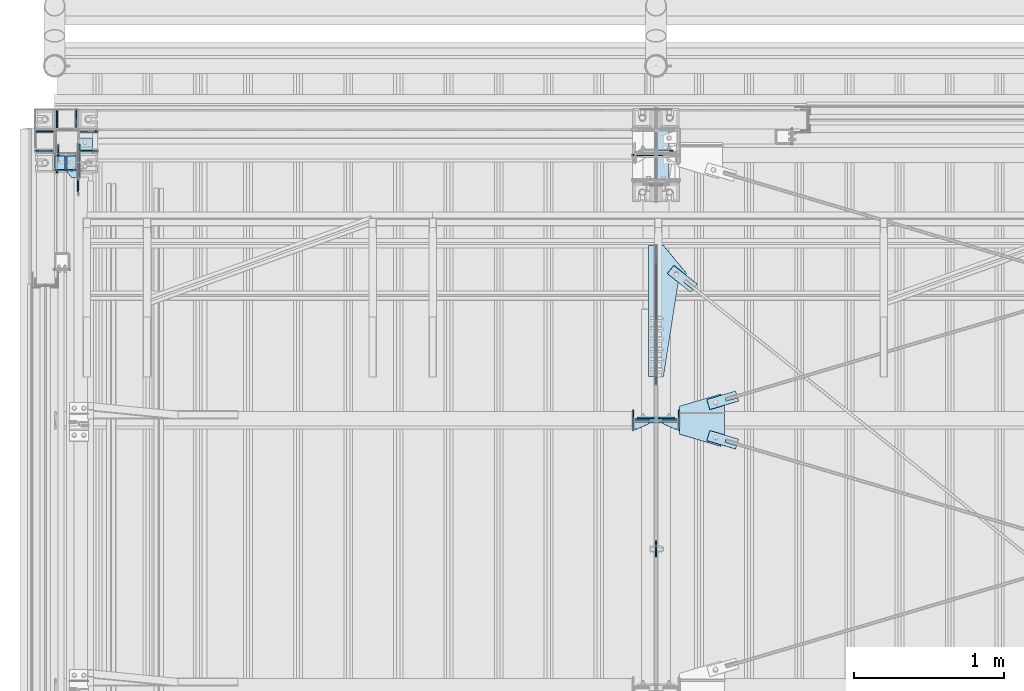
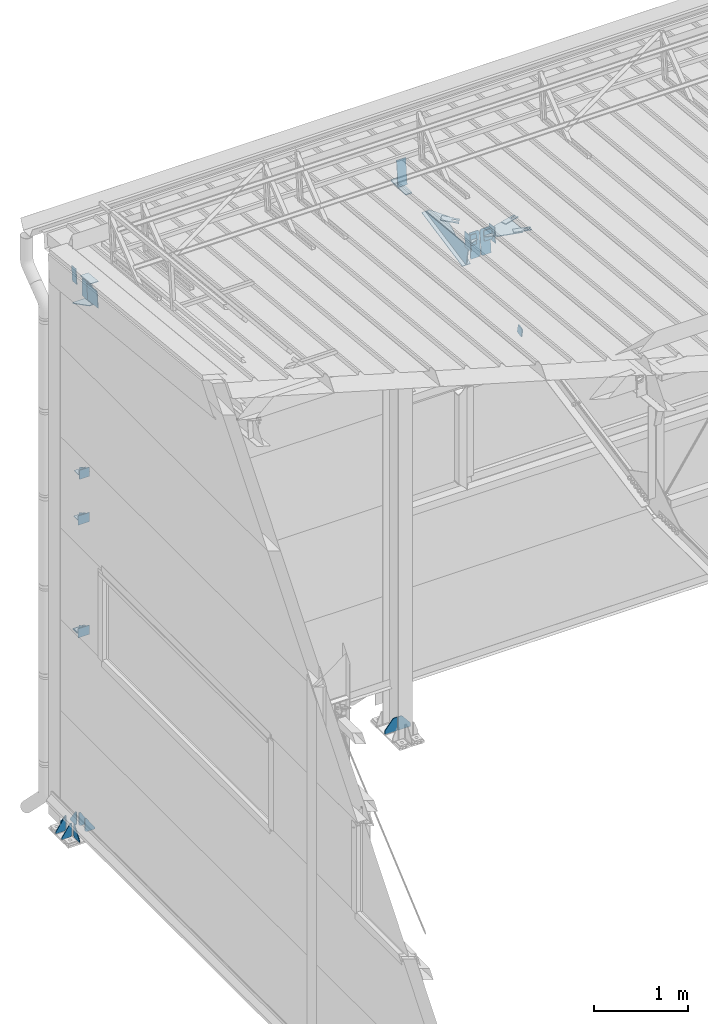
# One storey, part 132 of 709: 41 plates, 2 openings, 14 elements without a shape of their own.
"""IFC4 building model written with IfcOpenShell, lengths in millimetres."""

from ifc_helpers import new_model, si_unit, direction, frame, origin_with_axes, place, context, subcontext, project, spatial, line, indexed_curve, outline, extrude, material, element, aggregate, save


model = new_model("IFC4")

# Units and contexts
model_context = context("Model", 3, precision=0.2, world=origin_with_axes(), true_north=direction((0.0, 1.0)))
body_context = subcontext(model_context, "Body", "Model", "MODEL_VIEW")
ifc_project = project(units=[si_unit("LENGTHUNIT", "METRE", prefix="MILLI"), si_unit("AREAUNIT", "SQUARE_METRE"), si_unit("VOLUMEUNIT", "CUBIC_METRE"), si_unit("MASSUNIT", "GRAM", prefix="KILO"), si_unit("TIMEUNIT", "SECOND"), si_unit("PLANEANGLEUNIT", "RADIAN"), si_unit("SOLIDANGLEUNIT", "STERADIAN"), si_unit("THERMODYNAMICTEMPERATUREUNIT", "DEGREE_CELSIUS"), si_unit("LUMINOUSINTENSITYUNIT", "LUMEN")], contexts=[model_context])

# Site, building, storey
site_placement = place(None, origin_with_axes())
site = spatial("IfcSite", under=ifc_project, at=site_placement, CompositionType="ELEMENT")
building_placement = place(site_placement, origin_with_axes())
building = spatial("IfcBuilding", under=site, at=building_placement, Name="Undefined", CompositionType="ELEMENT")
storey_placement = place(building_placement, origin_with_axes())
storey = spatial("IfcBuildingStorey", under=building, at=storey_placement, Name="Undefined", CompositionType="ELEMENT", Elevation=0.0)

# Assembly, plates
assembly_1_placement = place(storey_placement, frame((4000.0, 21827.0, -200.0), z_axis=(-1.0, 0.0, 0.0), x_axis=(0.0, 0.0, 1.0)))
assembly_1 = element("IfcElementAssembly", 1, at=assembly_1_placement, inside=storey)
ifc_material = material(Name="C355-6", Category="STEEL")
plate_1_placement = place(assembly_1_placement, frame((7434.21546, 30.02526, -3.0), z_axis=(-0.099503719, 0.9950371902, 0.0), x_axis=(0.0, 0.0, -1.0)))
plate_1 = element("IfcPlate", 2, at=plate_1_placement, material=ifc_material, ObjectType="595", context=body_context, shape_type="SolidModel", body=[
    extrude(outline(indexed_curve([(0.0, 0.0), (114.0, 0.0), (114.0, 333.33554), (0.0, 333.33554)], segments=[line(1, 2, 3, 4, 1)])), frame((0.0, 0.0, 4.0), z_axis=(0.0, 0.0, 1.0), x_axis=(1.0, 0.0, 0.0)), (0.0, 0.0, -1.0), 8.0),
])
plate_2_placement = place(assembly_1_placement, frame((7097.93718, -163.0, -87.0), z_axis=(-1.0, 0.0, 0.0), x_axis=(0.0, 0.0, 1.0)))
plate_2 = element("IfcPlate", 3, at=plate_2_placement, material=ifc_material, ObjectType="461", context=body_context, shape_type="SolidModel", body=[
    extrude(outline(indexed_curve([(0.0, 0.0), (68.0, 0.0), (83.0, 15.0), (83.0, 311.0), (68.0, 326.0), (0.0, 326.0)], segments=[line(1, 2, 3, 4, 5, 6, 1)])), frame((0.0, 0.0, 4.0), z_axis=(0.0, 0.0, 1.0), x_axis=(1.0, 0.0, 0.0)), (0.0, 0.0, -1.0), 8.0),
])
plate_3_placement = place(assembly_1_placement, frame((25.0, 0.0, 3.0), z_axis=(0.0, 1.0, 0.0), x_axis=(0.0, 0.0, 1.0)))
plate_3 = element("IfcPlate", 4, at=plate_3_placement, material=ifc_material, ObjectType="417", context=body_context, shape_type="SolidModel", body=[
    extrude(outline(indexed_curve([(0.0, 0.0), (152.0, 0.0), (152.0, 50.0), (50.0, 175.0), (0.0, 175.0)], segments=[line(1, 2, 3, 4, 5, 1)])), frame((0.0, 0.0, 4.0), z_axis=(0.0, 0.0, 1.0), x_axis=(1.0, 0.0, 0.0)), (0.0, 0.0, -1.0), 8.0),
])
plate_4_placement = place(assembly_1_placement, frame((25.0, 0.0, -3.0), z_axis=(0.0, -1.0, 0.0), x_axis=(0.0, 0.0, -1.0)))
plate_4 = element("IfcPlate", 5, at=plate_4_placement, material=ifc_material, ObjectType="417", context=body_context, shape_type="SolidModel", body=[
    extrude(outline(indexed_curve([(0.0, 0.0), (152.0, 0.0), (152.0, 50.0), (50.0, 175.0), (0.0, 175.0)], segments=[line(1, 2, 3, 4, 5, 1)])), frame((0.0, 0.0, 4.0), z_axis=(0.0, 0.0, 1.0), x_axis=(1.0, 0.0, 0.0)), (0.0, 0.0, -1.0), 8.0),
])
aggregate(assembly_1, [plate_1, plate_2, plate_3, plate_4])

assembly_2_placement = place(storey_placement, frame((80.0, 21920.0, -200.0), z_axis=(0.0, -1.0, 0.0), x_axis=(0.0, 0.0, 1.0)))
assembly_2 = element("IfcElementAssembly", 6, at=assembly_2_placement, inside=storey)
plate_5_placement = place(assembly_2_placement, frame((2742.0, -63.0, 80.0), z_axis=(1.0, 0.0, 0.0), x_axis=(0.0, 1.0, 0.0)))
plate_5 = element("IfcPlate", 7, at=plate_5_placement, material=ifc_material, ObjectType="496", context=body_context, shape_type="SolidModel", body=[
    extrude(outline(indexed_curve([(0.0, 0.0), (143.0, 0.0), (143.0, 100.0), (0.0, 100.0)], segments=[line(1, 2, 3, 4, 1)])), frame((0.0, 0.0, 4.0), z_axis=(0.0, 0.0, 1.0), x_axis=(1.0, 0.0, 0.0)), (0.0, 0.0, -1.0), 8.0),
])
plate_6_placement = place(assembly_2_placement, frame((7006.92795, -92.0, 242.19452), z_axis=(0.9950371902, 0.0, -0.099503719), x_axis=(-0.099503719, 0.0, -0.9950371902)))
plate_6 = element("IfcPlate", 8, at=plate_6_placement, material=ifc_material, ObjectType="456", context=body_context, shape_type="SolidModel", body=[
    extrude(outline(indexed_curve([(0.0, 0.0), (162.60347, 0.0), (162.60347, 172.0), (142.60347, 172.0), (0.0, 59.5)], segments=[line(1, 2, 3, 4, 5, 1)])), frame((0.0, 0.0, 4.0), z_axis=(0.0, 0.0, 1.0), x_axis=(1.0, 0.0, 0.0)), (0.0, 0.0, -1.0), 8.0),
])
plate_7_placement = place(assembly_2_placement, frame((7241.79623, -81.0, 218.70769), z_axis=(0.0, -1.0, 0.0), x_axis=(-0.9950371902, 0.0, 0.099503719)))
plate_7 = element("IfcPlate", 9, at=plate_7_placement, material=ifc_material, ObjectType="455", context=body_context, shape_type="SolidModel", body=[
    extrude(outline(indexed_curve([(0.0, 0.0), (232.0397, 0.0), (232.0397, 162.60347), (226.06948, 222.3057), (0.0, 199.69876)], segments=[line(1, 2, 3, 4, 5, 1)])), frame((0.0, 0.0, 6.0), z_axis=(0.0, 0.0, 1.0), x_axis=(1.0, 0.0, 0.0)), (0.0, 0.0, -1.0), 12.0),
])
plate_8_placement = place(assembly_2_placement, frame((25.0, -80.0, -64.0), z_axis=(0.0, 0.0, 1.0), x_axis=(0.0, -1.0, 0.0)))
plate_8 = element("IfcPlate", 10, at=plate_8_placement, material=ifc_material, ObjectType="431", context=body_context, shape_type="SolidModel", body=[
    extrude(outline(indexed_curve([(0.0, 20.0), (20.0, 0.0), (125.0, 0.0), (125.0, 20.0), (20.0, 175.0), (0.0, 175.0)], segments=[line(1, 2, 3, 4, 5, 6, 1)])), frame((0.0, 0.0, 4.0), z_axis=(0.0, 0.0, 1.0), x_axis=(1.0, 0.0, 0.0)), (0.0, 0.0, -1.0), 8.0),
])
plate_9_placement = place(assembly_2_placement, frame((25.0, 64.0, -80.0), z_axis=(0.0, 1.0, 0.0), x_axis=(1.0, 0.0, 0.0)))
plate_9 = element("IfcPlate", 11, at=plate_9_placement, material=ifc_material, ObjectType="430", context=body_context, shape_type="SolidModel", body=[
    extrude(outline(indexed_curve([(0.0, 20.0), (20.0, 0.0), (175.0, 0.0), (175.0, 20.0), (20.0, 130.0), (0.0, 130.0)], segments=[line(1, 2, 3, 4, 5, 6, 1)])), frame((0.0, 0.0, 4.0), z_axis=(0.0, 0.0, 1.0), x_axis=(1.0, 0.0, 0.0)), (0.0, 0.0, -1.0), 8.0),
])
plate_10_placement = place(assembly_2_placement, frame((25.0, -80.0, 64.0), z_axis=(0.0, 0.0, 1.0), x_axis=(0.0, -1.0, 0.0)))
plate_10 = element("IfcPlate", 12, at=plate_10_placement, material=ifc_material, ObjectType="431", context=body_context, shape_type="SolidModel", body=[
    extrude(outline(indexed_curve([(0.0, 20.0), (20.0, 0.0), (125.0, 0.0), (125.0, 20.0), (20.0, 175.0), (0.0, 175.0)], segments=[line(1, 2, 3, 4, 5, 6, 1)])), frame((0.0, 0.0, 4.0), z_axis=(0.0, 0.0, 1.0), x_axis=(1.0, 0.0, 0.0)), (0.0, 0.0, -1.0), 8.0),
])
plate_11_placement = place(assembly_2_placement, frame((25.0, -64.0, -80.0), z_axis=(0.0, 1.0, 0.0), x_axis=(1.0, 0.0, 0.0)))
plate_11 = element("IfcPlate", 13, at=plate_11_placement, material=ifc_material, ObjectType="430", context=body_context, shape_type="SolidModel", body=[
    extrude(outline(indexed_curve([(0.0, 20.0), (20.0, 0.0), (175.0, 0.0), (175.0, 20.0), (20.0, 130.0), (0.0, 130.0)], segments=[line(1, 2, 3, 4, 5, 6, 1)])), frame((0.0, 0.0, 4.0), z_axis=(0.0, 0.0, 1.0), x_axis=(1.0, 0.0, 0.0)), (0.0, 0.0, -1.0), 8.0),
])
plate_12_placement = place(assembly_2_placement, frame((25.0, 205.0, -64.0), z_axis=(0.0, 0.0, 1.0), x_axis=(0.0, -1.0, 0.0)))
plate_12 = element("IfcPlate", 14, at=plate_12_placement, material=ifc_material, ObjectType="431", context=body_context, shape_type="SolidModel", body=[
    extrude(outline(indexed_curve([(0.0, 0.0), (105.0, 0.0), (125.0, 20.0), (125.0, 175.0), (105.0, 175.0), (0.0, 20.0)], segments=[line(1, 2, 3, 4, 5, 6, 1)])), frame((0.0, 0.0, 4.0), z_axis=(0.0, 0.0, 1.0), x_axis=(1.0, 0.0, 0.0)), (0.0, 0.0, -1.0), 8.0),
])
plate_13_placement = place(assembly_2_placement, frame((25.0, 205.0, 64.0), z_axis=(0.0, 0.0, 1.0), x_axis=(0.0, -1.0, 0.0)))
plate_13 = element("IfcPlate", 15, at=plate_13_placement, material=ifc_material, ObjectType="431", context=body_context, shape_type="SolidModel", body=[
    extrude(outline(indexed_curve([(0.0, 0.0), (105.0, 0.0), (125.0, 20.0), (125.0, 175.0), (105.0, 175.0), (0.0, 20.0)], segments=[line(1, 2, 3, 4, 5, 6, 1)])), frame((0.0, 0.0, 4.0), z_axis=(0.0, 0.0, 1.0), x_axis=(1.0, 0.0, 0.0)), (0.0, 0.0, -1.0), 8.0),
])
plate_14_placement = place(assembly_2_placement, frame((25.0, 64.0, 80.0), z_axis=(0.0, -1.0, 0.0), x_axis=(1.0, 0.0, 0.0)))
plate_14 = element("IfcPlate", 16, at=plate_14_placement, material=ifc_material, ObjectType="430", context=body_context, shape_type="SolidModel", body=[
    extrude(outline(indexed_curve([(0.0, 20.0), (20.0, 0.0), (175.0, 0.0), (175.0, 20.0), (20.0, 130.0), (0.0, 130.0)], segments=[line(1, 2, 3, 4, 5, 6, 1)])), frame((0.0, 0.0, 4.0), z_axis=(0.0, 0.0, 1.0), x_axis=(1.0, 0.0, 0.0)), (0.0, 0.0, -1.0), 8.0),
])
aggregate(assembly_2, [plate_5, plate_6, plate_7, plate_8, plate_9, plate_10, plate_11, plate_12, plate_13, plate_14])

assembly_3_placement = place(storey_placement, frame((4000.0, 21654.0, 7089.70002), z_axis=(-1.0, 0.0, 0.0), x_axis=(0.0, -0.9950371902, 0.099503719)))
assembly_3 = element("IfcElementAssembly", 17, at=assembly_3_placement, inside=storey)
plate_15_placement = place(assembly_3_placement, frame((412.62035, -176.8248, 50.0), z_axis=(0.2927142719, 0.9561999556, 0.0), x_axis=(0.9561999556, -0.2927142719, 0.0)))
plate_15 = element("IfcPlate", 18, at=plate_15_placement, material=ifc_material, ObjectType="489", context=body_context, shape_type="SolidModel", body=[
    extrude(outline(indexed_curve([(0.0, 0.0), (887.65935, 0.0), (887.65935, 100.0), (259.05365, 196.23068), (189.37305, 253.1922), (0.0, 100.0)], segments=[line(1, 2, 3, 4, 5, 6, 1)])), frame((0.0, 0.0, 4.0), z_axis=(0.0, 0.0, 1.0), x_axis=(1.0, 0.0, 0.0)), (0.0, 0.0, -1.0), 8.0),
])
plate_16_placement = place(assembly_3_placement, frame((1342.111, -173.0, 0.0), z_axis=(0.0, 0.0, 1.0), x_axis=(-1.0, 0.0, 0.0)))
plate_16 = element("IfcPlate", 19, at=plate_16_placement, material=ifc_material, ObjectType="449", context=body_context, shape_type="SolidModel", body=[
    extrude(outline(indexed_curve([(0.0, 0.0), (928.3198, 0.0), (79.53997, 259.83056)], segments=[line(1, 2, 3, 1)])), frame((0.0, 0.0, 6.0), z_axis=(0.0, 0.0, 1.0), x_axis=(1.0, 0.0, 0.0)), (0.0, 0.0, -1.0), 12.0),
])
plate_17_placement = place(assembly_3_placement, frame((1597.87962, 163.0, 127.0), z_axis=(-1.0, 0.0, 0.0), x_axis=(0.0, 0.0, -1.0)))
plate_17 = element("IfcPlate", 20, at=plate_17_placement, material=ifc_material, ObjectType="585", context=body_context, shape_type="SolidModel", body=[
    extrude(outline(indexed_curve([(0.0, 0.0), (108.0, 0.0), (123.0, 15.0), (123.0, 311.0), (108.0, 326.0), (0.0, 326.0)], segments=[line(1, 2, 3, 4, 5, 6, 1)])), frame((0.0, 0.0, 4.0), z_axis=(0.0, 0.0, 1.0), x_axis=(1.0, 0.0, 0.0)), (0.0, 0.0, -1.0), 8.0),
])
plate_18_placement = place(assembly_3_placement, frame((1597.88359, 163.0, -127.0), z_axis=(1.0, 0.0, 0.0), x_axis=(0.0, 0.0, 1.0)))
plate_18 = element("IfcPlate", 21, at=plate_18_placement, material=ifc_material, ObjectType="585", context=body_context, shape_type="SolidModel", body=[
    extrude(outline(indexed_curve([(0.0, 0.0), (108.0, 0.0), (123.0, 15.0), (123.0, 311.0), (108.0, 326.0), (0.0, 326.0)], segments=[line(1, 2, 3, 4, 5, 6, 1)])), frame((0.0, 0.0, 4.0), z_axis=(0.0, 0.0, 1.0), x_axis=(1.0, 0.0, 0.0)), (0.0, 0.0, -1.0), 8.0),
])
aggregate(assembly_3, [plate_15, plate_16, plate_17, plate_18])

# Assembly, plate
assembly_4_placement = place(storey_placement, frame((162.5, 21654.0, 6929.907), z_axis=(-1.0, 0.0, 0.0), x_axis=(0.0, -0.9950371902, 0.099503719)))
assembly_4 = element("IfcElementAssembly", 22, at=assembly_4_placement, inside=storey)
plate_19_placement = place(assembly_4_placement, frame((84.87182, 105.0, 6.5), z_axis=(0.0, 0.0, -1.0), x_axis=(0.0, -1.0, 0.0)))
plate_19 = element("IfcPlate", 23, at=plate_19_placement, material=ifc_material, ObjectType="453", context=body_context, shape_type="SolidModel", body=[
    extrude(outline(indexed_curve([(0.0, 0.0), (210.0, 0.0), (210.0, 220.0), (0.0, 220.0)], segments=[line(1, 2, 3, 4, 1)])), frame((0.0, 0.0, 4.0), z_axis=(0.0, 0.0, 1.0), x_axis=(1.0, 0.0, 0.0)), (0.0, 0.0, -1.0), 8.0),
])
aggregate(assembly_4, [plate_19])

assembly_5_placement = place(storey_placement, frame((4000.0, 21144.45166, 6946.69226), z_axis=(-0.625451877, -0.7802627439, 1e-10), x_axis=(0.7742288439, -0.6206151549, -0.124123031)))
assembly_5 = element("IfcElementAssembly", 24, at=assembly_5_placement, inside=storey)
plate_20_placement = place(assembly_5_placement, frame((325.65866, 5.35577, -34.5878), z_axis=(1e-10, 0.9882227648, 0.1530221135), x_axis=(-1.0, 0.0, 0.0)))
plate_20 = element("IfcPlate", 25, at=plate_20_placement, material=ifc_material, ObjectType="490", context=body_context, shape_type="SolidModel", body=[
    extrude(outline(indexed_curve([(0.0, 0.0), (200.0, 0.0), (200.0, 70.0), (0.0, 70.0), (0.0, 46.0), (80.0, 46.0), (80.0, 24.0), (0.0, 24.0)], segments=[line(1, 2, 3, 4, 5, 6, 7, 8, 1)])), frame((0.0, 0.0, 4.0), z_axis=(0.0, 0.0, 1.0), x_axis=(1.0, 0.0, 0.0)), (0.0, 0.0, -1.0), 8.0),
])
aggregate(assembly_5, [plate_20])

assembly_6_placement = place(storey_placement, frame((4000.0, 19241.53388, 6684.40595), z_axis=(1.0, 0.0, 0.0), x_axis=(0.0, -0.9805806757, -0.1961161349)))
assembly_6 = element("IfcElementAssembly", 26, at=assembly_6_placement, inside=storey)
plate_21_placement = place(assembly_6_placement, origin_with_axes())
plate_21 = element("IfcPlate", 27, at=plate_21_placement, material=ifc_material, ObjectType="491", context=body_context, shape_type="SolidModel", body=[
    extrude(outline(indexed_curve([(0.0, 0.0), (90.0, 0.0), (90.0, 110.0), (0.0, 110.0)], segments=[line(1, 2, 3, 4, 1)])), frame((0.0, 0.0, 6.0), z_axis=(0.0, 0.0, 1.0), x_axis=(1.0, 0.0, 0.0)), (0.0, 0.0, -1.0), 12.0),
])
aggregate(assembly_6, [plate_21])

# Assembly, plates
assembly_7_placement = place(storey_placement, frame((50.0, 21920.0, 2550.0), z_axis=(0.0, 0.0, -1.0), x_axis=(0.0, -1.0, 0.0)))
assembly_7 = element("IfcElementAssembly", 28, at=assembly_7_placement, inside=storey)
plate_22_placement = place(assembly_7_placement, frame((194.0, -93.0, -60.0), z_axis=(-1.0, 0.0, 0.0), x_axis=(0.0, 0.0, 1.0)))
plate_22 = element("IfcPlate", 29, at=plate_22_placement, material=ifc_material, ObjectType="495", context=body_context, shape_type="SolidModel", body=[
    extrude(outline(indexed_curve([(0.0, 0.0), (120.0, 0.0), (120.0, 140.0), (0.0, 140.0)], segments=[line(1, 2, 3, 4, 1)])), frame((0.0, 0.0, 4.0), z_axis=(0.0, 0.0, 1.0), x_axis=(1.0, 0.0, 0.0)), (0.0, 0.0, -1.0), 8.0),
])
plate_23_placement = place(assembly_7_placement, frame((190.0, -23.0, -60.0), z_axis=(0.0, 1.0, 0.0), x_axis=(-1.0, 0.0, 0.0)))
plate_23 = element("IfcPlate", 30, at=plate_23_placement, material=ifc_material, ObjectType="498", context=body_context, shape_type="SolidModel", body=[
    extrude(outline(indexed_curve([(0.0, 0.0), (20.0, 0.0), (90.0, 36.0), (90.0, 56.0), (0.0, 56.0)], segments=[line(1, 2, 3, 4, 5, 1)])), frame((0.0, 0.0, 4.0), z_axis=(0.0, 0.0, 1.0), x_axis=(1.0, 0.0, 0.0)), (0.0, 0.0, -1.0), 8.0),
])
plate_24_placement = place(assembly_7_placement, frame((100.0, 47.0, 0.0), z_axis=(0.0, 0.0, -1.0), x_axis=(1.0, 0.0, 0.0)))
plate_24 = element("IfcPlate", 31, at=plate_24_placement, material=ifc_material, ObjectType="497", context=body_context, shape_type="SolidModel", body=[
    extrude(outline(indexed_curve([(0.0, 0.0), (90.0, 0.0), (90.0, 140.0), (0.0, 140.0)], segments=[line(1, 2, 3, 4, 1)])), frame((0.0, 0.0, 4.0), z_axis=(0.0, 0.0, 1.0), x_axis=(1.0, 0.0, 0.0)), (0.0, 0.0, -1.0), 8.0),
])
aggregate(assembly_7, [plate_22, plate_23, plate_24])

assembly_8_placement = place(storey_placement, frame((50.0, 21920.0, 4020.0), z_axis=(0.0, 0.0, -1.0), x_axis=(0.0, -1.0, 0.0)))
assembly_8 = element("IfcElementAssembly", 32, at=assembly_8_placement, inside=storey)
plate_25_placement = place(assembly_8_placement, frame((100.0, 47.0, 0.0), z_axis=(0.0, 0.0, -1.0), x_axis=(1.0, 0.0, 0.0)))
plate_25 = element("IfcPlate", 33, at=plate_25_placement, material=ifc_material, ObjectType="497", context=body_context, shape_type="SolidModel", body=[
    extrude(outline(indexed_curve([(0.0, 0.0), (90.0, 0.0), (90.0, 140.0), (0.0, 140.0)], segments=[line(1, 2, 3, 4, 1)])), frame((0.0, 0.0, 4.0), z_axis=(0.0, 0.0, 1.0), x_axis=(1.0, 0.0, 0.0)), (0.0, 0.0, -1.0), 8.0),
])
plate_26_placement = place(assembly_8_placement, frame((190.0, -23.0, -60.0), z_axis=(0.0, 1.0, 0.0), x_axis=(-1.0, 0.0, 0.0)))
plate_26 = element("IfcPlate", 34, at=plate_26_placement, material=ifc_material, ObjectType="498", context=body_context, shape_type="SolidModel", body=[
    extrude(outline(indexed_curve([(0.0, 0.0), (20.0, 0.0), (90.0, 36.0), (90.0, 56.0), (0.0, 56.0)], segments=[line(1, 2, 3, 4, 5, 1)])), frame((0.0, 0.0, 4.0), z_axis=(0.0, 0.0, 1.0), x_axis=(1.0, 0.0, 0.0)), (0.0, 0.0, -1.0), 8.0),
])
plate_27_placement = place(assembly_8_placement, frame((194.0, -93.0, -60.0), z_axis=(-1.0, 0.0, 0.0), x_axis=(0.0, 0.0, 1.0)))
plate_27 = element("IfcPlate", 35, at=plate_27_placement, material=ifc_material, ObjectType="495", context=body_context, shape_type="SolidModel", body=[
    extrude(outline(indexed_curve([(0.0, 0.0), (120.0, 0.0), (120.0, 140.0), (0.0, 140.0)], segments=[line(1, 2, 3, 4, 1)])), frame((0.0, 0.0, 4.0), z_axis=(0.0, 0.0, 1.0), x_axis=(1.0, 0.0, 0.0)), (0.0, 0.0, -1.0), 8.0),
])
aggregate(assembly_8, [plate_25, plate_26, plate_27])

assembly_9_placement = place(storey_placement, frame((80.0, 21920.0, 4610.0), z_axis=(0.0, 0.0, -1.0), x_axis=(0.0, -1.0, 0.0)))
assembly_9 = element("IfcElementAssembly", 36, at=assembly_9_placement, inside=storey)
plate_28_placement = place(assembly_9_placement, frame((190.0, 0.0, -60.0), z_axis=(0.0, 1.0, 0.0), x_axis=(-1.0, 0.0, 0.0)))
plate_28 = element("IfcPlate", 37, at=plate_28_placement, material=ifc_material, ObjectType="498", context=body_context, shape_type="SolidModel", body=[
    extrude(outline(indexed_curve([(0.0, 0.0), (20.0, 0.0), (90.0, 36.0), (90.0, 56.0), (0.0, 56.0)], segments=[line(1, 2, 3, 4, 5, 1)])), frame((0.0, 0.0, 4.0), z_axis=(0.0, 0.0, 1.0), x_axis=(1.0, 0.0, 0.0)), (0.0, 0.0, -1.0), 8.0),
])
plate_29_placement = place(assembly_9_placement, frame((190.0, -70.0, 0.0), z_axis=(0.0, 0.0, -1.0), x_axis=(-1.0, 0.0, 0.0)))
plate_29 = element("IfcPlate", 38, at=plate_29_placement, material=ifc_material, ObjectType="497", context=body_context, shape_type="SolidModel", body=[
    extrude(outline(indexed_curve([(0.0, 0.0), (90.0, 0.0), (90.0, 140.0), (0.0, 140.0)], segments=[line(1, 2, 3, 4, 1)])), frame((0.0, 0.0, 4.0), z_axis=(0.0, 0.0, 1.0), x_axis=(1.0, 0.0, 0.0)), (0.0, 0.0, -1.0), 8.0),
])
plate_30_placement = place(assembly_9_placement, frame((194.0, -60.0, -60.0), z_axis=(-1.0, 0.0, 0.0), x_axis=(0.0, 0.0, 1.0)))
plate_30 = element("IfcPlate", 39, at=plate_30_placement, material=ifc_material, ObjectType="503", context=body_context, shape_type="SolidModel", body=[
    extrude(outline(indexed_curve([(0.0, 0.0), (120.0, 0.0), (120.0, 120.0), (0.0, 120.0)], segments=[line(1, 2, 3, 4, 1)])), frame((0.0, 0.0, 4.0), z_axis=(0.0, 0.0, 1.0), x_axis=(1.0, 0.0, 0.0)), (0.0, 0.0, -1.0), 8.0),
])
aggregate(assembly_9, [plate_28, plate_29, plate_30])

# Assembly, plate, voiding feature
assembly_10_placement = place(storey_placement, frame((4000.0, 20064.14591, 7330.08943), z_axis=(-0.2852311229, -0.9537021177, 0.0953702118), x_axis=(0.9584587662, -0.2838155751, 0.028381558)))
assembly_10 = element("IfcElementAssembly", 40, at=assembly_10_placement, inside=storey)
plate_31_placement = place(assembly_10_placement, frame((363.0251, 0.0, -35.0), z_axis=(0.0, 1.0, 0.0), x_axis=(0.0, 0.0, 1.0)))
plate_31 = element("IfcPlate", 41, at=plate_31_placement, material=ifc_material, ObjectType="574", context=body_context, shape_type="SolidModel", body=[
    extrude(outline(indexed_curve([(0.0, 0.0), (70.0, 0.0), (70.0, 200.0), (0.0, 200.0)], segments=[line(1, 2, 3, 4, 1)])), frame((0.0, 0.0, 4.0), z_axis=(0.0, 0.0, 1.0), x_axis=(1.0, 0.0, 0.0)), (0.0, 0.0, -1.0), 8.0),
])
voiding_feature_1_placement = place(plate_31_placement, frame((24.0, 120.0, 0.0), z_axis=(0.0, 0.0, 1.0), x_axis=(1.0, 0.0, 0.0)))
element("IfcVoidingFeature", 42, at=voiding_feature_1_placement, cuts=plate_31, Name="PLATE", PredefinedType="HOLE", context=body_context, shape_type="SolidModel", body=[
    extrude(outline(indexed_curve([(0.0, 0.0), (22.0, 0.0), (22.0, 85.0), (0.0, 85.0)], segments=[line(1, 2, 3, 4, 1)])), frame((0.0, 0.0, 6.5), z_axis=(0.0, 0.0, 1.0), x_axis=(1.0, 0.0, 0.0)), (0.0, 0.0, -1.0), 13.0),
])
aggregate(assembly_10, [plate_31])

assembly_11_placement = place(storey_placement, frame((4000.0, 20064.14591, 7330.08943), z_axis=(0.2852311229, -0.9537021177, 0.0953702118), x_axis=(0.9584587662, 0.2838155751, -0.028381558)))
assembly_11 = element("IfcElementAssembly", 43, at=assembly_11_placement, inside=storey)
plate_32_placement = place(assembly_11_placement, frame((363.0251, 0.0, -35.0), z_axis=(0.0, 1.0, 0.0), x_axis=(0.0, 0.0, 1.0)))
plate_32 = element("IfcPlate", 44, at=plate_32_placement, material=ifc_material, ObjectType="574", context=body_context, shape_type="SolidModel", body=[
    extrude(outline(indexed_curve([(0.0, 0.0), (70.0, 0.0), (70.0, 200.0), (0.0, 200.0)], segments=[line(1, 2, 3, 4, 1)])), frame((0.0, 0.0, 4.0), z_axis=(0.0, 0.0, 1.0), x_axis=(1.0, 0.0, 0.0)), (0.0, 0.0, -1.0), 8.0),
])
voiding_feature_2_placement = place(plate_32_placement, frame((24.0, 120.0, 0.0), z_axis=(0.0, 0.0, 1.0), x_axis=(1.0, 0.0, 0.0)))
element("IfcVoidingFeature", 45, at=voiding_feature_2_placement, cuts=plate_32, Name="PLATE", PredefinedType="HOLE", context=body_context, shape_type="SolidModel", body=[
    extrude(outline(indexed_curve([(0.0, 0.0), (22.0, 0.0), (22.0, 85.0), (0.0, 85.0)], segments=[line(1, 2, 3, 4, 1)])), frame((0.0, 0.0, 6.5), z_axis=(0.0, 0.0, 1.0), x_axis=(1.0, 0.0, 0.0)), (0.0, 0.0, -1.0), 13.0),
])
aggregate(assembly_11, [plate_32])

# Assembly, plates
assembly_12_placement = place(storey_placement, frame((4000.0, 20063.34988, 7322.08923), z_axis=(0.0, -0.9950371902, 0.099503719), x_axis=(-1.0, 0.0, 0.0)))
assembly_12 = element("IfcElementAssembly", 46, at=assembly_12_placement, inside=storey)
plate_33_placement = place(assembly_12_placement, frame((47.0, -65.0, 0.0), z_axis=(0.0, 0.0, 1.0), x_axis=(1.0, 0.0, 0.0)))
plate_33 = element("IfcPlate", 47, at=plate_33_placement, material=ifc_material, ObjectType="587", context=body_context, shape_type="SolidModel", body=[
    extrude(outline(indexed_curve([(0.0, 0.0), (100.0, 0.0), (100.0, 130.0), (0.0, 130.0)], segments=[line(1, 2, 3, 4, 1)])), frame((0.0, 0.0, 4.0), z_axis=(0.0, 0.0, 1.0), x_axis=(1.0, 0.0, 0.0)), (0.0, 0.0, -1.0), 8.0),
])
plate_34_placement = place(assembly_12_placement, frame((47.0, 0.0, 60.0), z_axis=(0.0, 1.0, 0.0), x_axis=(1.0, 0.0, 0.0)))
plate_34 = element("IfcPlate", 48, at=plate_34_placement, material=ifc_material, ObjectType="588", context=body_context, shape_type="SolidModel", body=[
    extrude(outline(indexed_curve([(0.0, 36.0), (80.0, 0.0), (100.0, 0.0), (100.0, 56.0), (0.0, 56.0)], segments=[line(1, 2, 3, 4, 5, 1)])), frame((0.0, 0.0, 4.0), z_axis=(0.0, 0.0, 1.0), x_axis=(1.0, 0.0, 0.0)), (0.0, 0.0, -1.0), 8.0),
])
plate_35_placement = place(assembly_12_placement, frame((151.0, -98.0, -60.0), z_axis=(-1.0, 0.0, 0.0), x_axis=(0.0, 0.0, 1.0)))
plate_35 = element("IfcPlate", 49, at=plate_35_placement, material=ifc_material, ObjectType="586", context=body_context, shape_type="SolidModel", body=[
    extrude(outline(indexed_curve([(0.0, 0.0), (120.0, 0.0), (120.0, 196.0), (0.0, 196.0)], segments=[line(1, 2, 3, 4, 1)])), frame((0.0, 0.0, 4.0), z_axis=(0.0, 0.0, 1.0), x_axis=(1.0, 0.0, 0.0)), (0.0, 0.0, -1.0), 8.0),
])
aggregate(assembly_12, [plate_33, plate_34, plate_35])

assembly_13_placement = place(storey_placement, frame((4000.0, 21840.04963, 7144.41925), z_axis=(0.0, -0.9950371902, 0.099503719), x_axis=(-1.0, 0.0, 0.0)))
assembly_13 = element("IfcElementAssembly", 50, at=assembly_13_placement, inside=storey)
plate_36_placement = place(assembly_13_placement, frame((3848.0, 103.9603, 110.0), z_axis=(0.0, -1.0, 0.0), x_axis=(-1.0, 0.0, 0.0)))
plate_36 = element("IfcPlate", 51, at=plate_36_placement, material=ifc_material, ObjectType="591", context=body_context, shape_type="SolidModel", body=[
    extrude(outline(indexed_curve([(0.0, 0.0), (100.0, 0.0), (100.0, 220.0), (0.0, 220.0)], segments=[line(1, 2, 3, 4, 1)])), frame((0.0, 0.0, 4.0), z_axis=(0.0, 0.0, 1.0), x_axis=(1.0, 0.0, 0.0)), (0.0, 0.0, -1.0), 8.0),
])
plate_37_placement = place(assembly_13_placement, frame((3976.0, -97.0, 47.0), z_axis=(1.0, 0.0, 0.0), x_axis=(0.0, 0.0, -1.0)))
plate_37 = element("IfcPlate", 52, at=plate_37_placement, material=ifc_material, ObjectType="592", context=body_context, shape_type="SolidModel", body=[
    extrude(outline(indexed_curve([(0.0, 0.0), (94.0, 0.0), (94.0, 194.0), (0.0, 194.0)], segments=[line(1, 2, 3, 4, 1)])), frame((0.0, 0.0, 4.0), z_axis=(0.0, 0.0, 1.0), x_axis=(1.0, 0.0, 0.0)), (0.0, 0.0, -1.0), 8.0),
])
aggregate(assembly_13, [plate_36, plate_37])

assembly_14_placement = place(storey_placement, frame((10000.0, 20063.34988, 7322.12913), z_axis=(0.0, -0.9950371902, 0.099503719), x_axis=(-1.0, 0.0, 0.0)))
assembly_14 = element("IfcElementAssembly", 53, at=assembly_14_placement, inside=storey)
plate_38_placement = place(assembly_14_placement, frame((5845.00055, 0.0, -93.07721), z_axis=(0.0, -1.0, 0.0), x_axis=(0.0, 0.0, 1.0)))
plate_38 = element("IfcPlate", 54, at=plate_38_placement, material=ifc_material, ObjectType="576", context=body_context, shape_type="SolidModel", body=[
    extrude(outline(indexed_curve([(0.0, 0.0), (186.15442, 0.0), (268.27702, 275.95562), (182.01573, 301.62642), (4.13868, 301.62642), (-82.1226, 275.95562)], segments=[line(1, 2, 3, 4, 5, 6, 1)])), frame((0.0, 0.0, 4.0), z_axis=(0.0, 0.0, 1.0), x_axis=(1.0, 0.0, 0.0)), (0.0, 0.0, -1.0), 8.0),
])
plate_39_placement = place(assembly_14_placement, frame((5849.0, -98.0, 60.0), z_axis=(1.0, 0.0, 0.0), x_axis=(0.0, 0.0, -1.0)))
plate_39 = element("IfcPlate", 55, at=plate_39_placement, material=ifc_material, ObjectType="586", context=body_context, shape_type="SolidModel", body=[
    extrude(outline(indexed_curve([(0.0, 0.0), (120.0, 0.0), (120.0, 196.0), (0.0, 196.0)], segments=[line(1, 2, 3, 4, 1)])), frame((0.0, 0.0, 4.0), z_axis=(0.0, 0.0, 1.0), x_axis=(1.0, 0.0, 0.0)), (0.0, 0.0, -1.0), 8.0),
])
plate_40_placement = place(assembly_14_placement, frame((5953.0, 0.0, 60.0), z_axis=(0.0, -1.0, 0.0), x_axis=(-1.0, 0.0, 0.0)))
plate_40 = element("IfcPlate", 56, at=plate_40_placement, material=ifc_material, ObjectType="588", context=body_context, shape_type="SolidModel", body=[
    extrude(outline(indexed_curve([(0.0, 36.0), (80.0, 0.0), (100.0, 0.0), (100.0, 56.0), (0.0, 56.0)], segments=[line(1, 2, 3, 4, 5, 1)])), frame((0.0, 0.0, 4.0), z_axis=(0.0, 0.0, 1.0), x_axis=(1.0, 0.0, 0.0)), (0.0, 0.0, -1.0), 8.0),
])
plate_41_placement = place(assembly_14_placement, frame((5953.0, 65.0, 0.0), z_axis=(0.0, 0.0, 1.0), x_axis=(-1.0, 0.0, 0.0)))
plate_41 = element("IfcPlate", 57, at=plate_41_placement, material=ifc_material, ObjectType="587", context=body_context, shape_type="SolidModel", body=[
    extrude(outline(indexed_curve([(0.0, 0.0), (100.0, 0.0), (100.0, 130.0), (0.0, 130.0)], segments=[line(1, 2, 3, 4, 1)])), frame((0.0, 0.0, 4.0), z_axis=(0.0, 0.0, 1.0), x_axis=(1.0, 0.0, 0.0)), (0.0, 0.0, -1.0), 8.0),
])
aggregate(assembly_14, [plate_38, plate_39, plate_40, plate_41])

save(model, "model.ifc")
